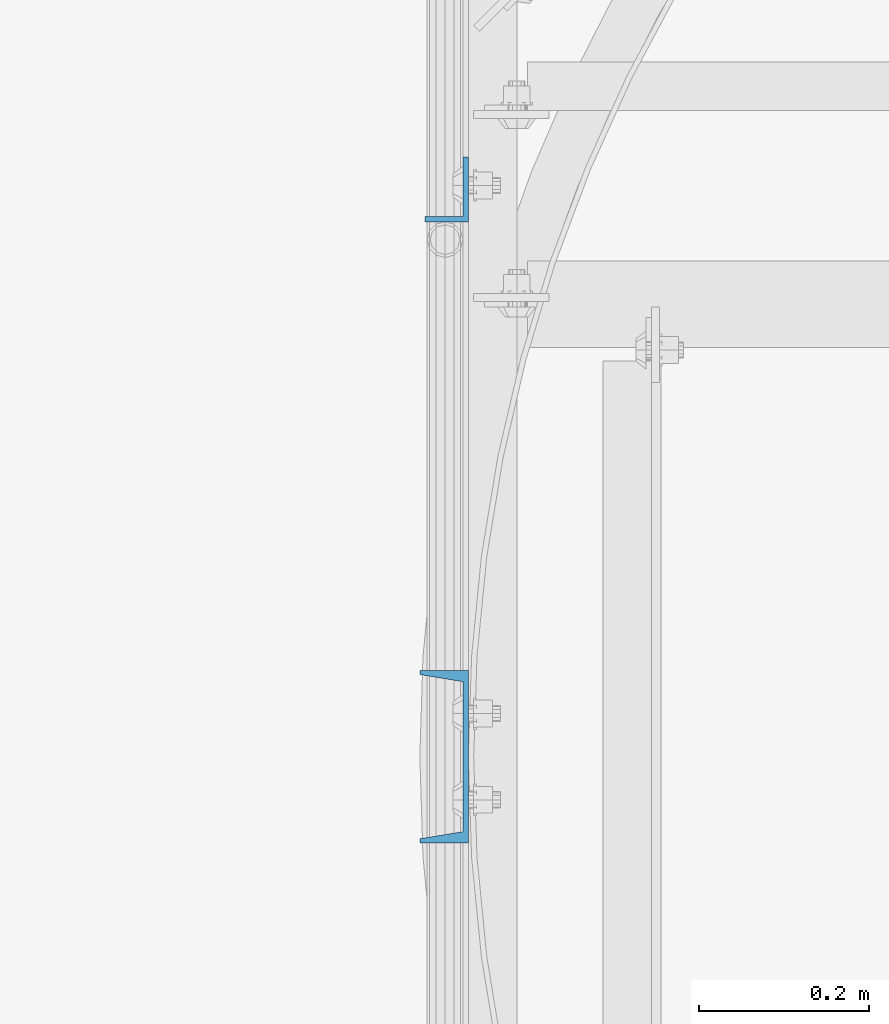
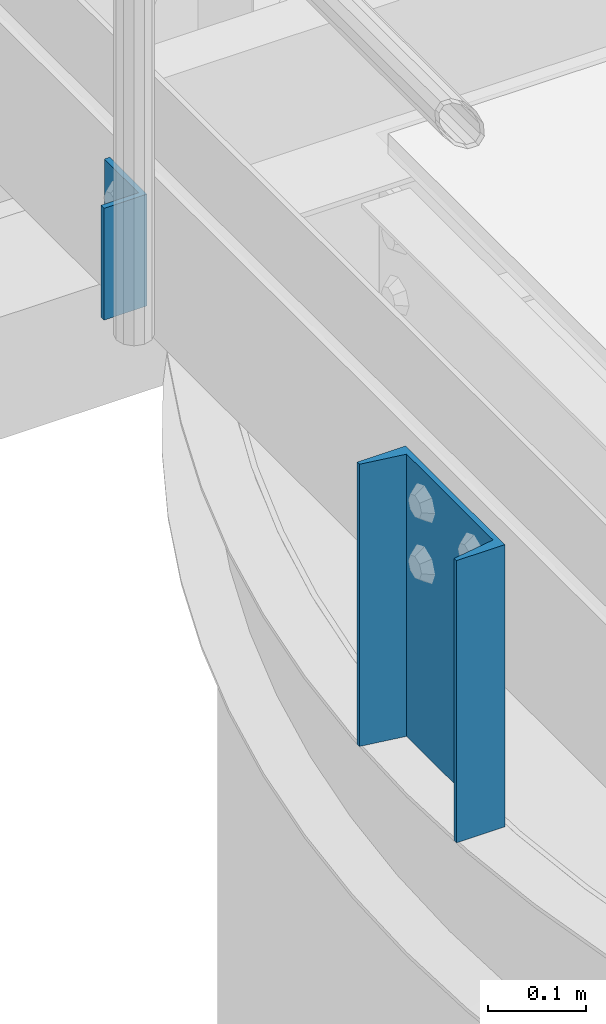
# One storey, part 797 of 1876: 2 columns, 2 elements without a shape of their own.
"""IFC2X3 building model written with IfcOpenShell, lengths in millimetres."""

from ifc_helpers import new_model, si_unit, frame, origin_with_axes, place, context, subcontext, project, spatial, faceted_brep, material, type_object, element, aggregate, save


model = new_model("IFC2X3")

# Units and contexts
model_context = context("Model", 3, precision=1e-05, world=origin_with_axes())
body_context = subcontext(model_context, "Body", "Model", "MODEL_VIEW")
ifc_project = project(units=[si_unit("LENGTHUNIT", "METRE", prefix="MILLI"), si_unit("AREAUNIT", "SQUARE_METRE"), si_unit("VOLUMEUNIT", "CUBIC_METRE"), si_unit("MASSUNIT", "GRAM", prefix="KILO"), si_unit("TIMEUNIT", "SECOND"), si_unit("PLANEANGLEUNIT", "RADIAN"), si_unit("SOLIDANGLEUNIT", "STERADIAN"), si_unit("THERMODYNAMICTEMPERATUREUNIT", "DEGREE_CELSIUS"), si_unit("LUMINOUSINTENSITYUNIT", "LUMEN")], contexts=[model_context])

# Site, building, storey
site_placement = place(None, origin_with_axes())
site = spatial("IfcSite", under=ifc_project, at=site_placement, CompositionType="ELEMENT")
building_placement = place(site_placement, origin_with_axes())
building = spatial("IfcBuilding", under=site, at=building_placement, Name="Undefined", CompositionType="ELEMENT")
storey_placement = place(building_placement, origin_with_axes())
storey = spatial("IfcBuildingStorey", under=building, at=storey_placement, Name="Undefined", CompositionType="ELEMENT", Elevation=0.0)

# Assembly, column
assembly_1_placement = place(storey_placement, origin_with_axes())
assembly_1 = element("IfcElementAssembly", 1, at=assembly_1_placement, inside=storey, Name="HANDRAIL", AssemblyPlace="NOTDEFINED", PredefinedType="RIGID_FRAME")
ifc_material = material(Name="STEEL/A36")
column_type_1 = type_object("IfcColumnType", Name="L3X2X1/4", PredefinedType="NOTDEFINED")
column_1_placement = place(assembly_1_placement, frame((3340.10333884985, -8868.88235546873, 7826.375), z_axis=(0.0, 1.0, 0.0), x_axis=(0.0, 0.0, 1.0)))
column_1 = element("IfcColumn", 2, at=column_1_placement, type_object=column_type_1, material=ifc_material, Name="ANGLE", ObjectType="L3X2X1/4", context=body_context, shape_type="Brep", body=[
    faceted_brep([(0.0, 25.3999999999996, -38.1000000000004), (0.0, 25.3999999999996, 38.1000000000004), (139.7, 25.3999999999996, 38.1000000000004), (139.7, 25.3999999999996, -38.1000000000004), (0.0, 19.0500000000002, 38.1000000000004), (139.7, 19.0500000000002, 38.1000000000004), (0.0, 19.0500000000002, -31.75), (139.7, 19.0500000000002, -31.75), (0.0, -25.3999999999996, -31.75), (139.7, -25.3999999999996, -31.75), (0.0, -25.3999999999996, -38.1000000000004), (139.7, -25.3999999999996, -38.1000000000004)], [[[0, 1, 2, 3]], [[1, 4, 5, 2]], [[4, 6, 7, 5]], [[6, 8, 9, 7]], [[8, 10, 11, 9]], [[10, 0, 3, 11]], [[5, 7, 9, 11, 3, 2]], [[10, 8, 6, 4, 1, 0]]]),
])
aggregate(assembly_1, [column_1])

assembly_2_placement = place(storey_placement, origin_with_axes())
assembly_2 = element("IfcElementAssembly", 3, at=assembly_2_placement, inside=storey, Name="BEAM", AssemblyPlace="NOTDEFINED", PredefinedType="RIGID_FRAME")
column_type_2 = type_object("IfcColumnType", Name="C8X11.5", PredefinedType="NOTDEFINED")
column_2_placement = place(assembly_2_placement, frame((3336.92833884985, -9537.66437988218, 7620.01566278096), z_axis=(0.0, 1.0, 0.0), x_axis=(0.0, 0.0, 1.0)))
column_2 = element("IfcColumn", 4, at=column_2_placement, type_object=column_type_2, material=ifc_material, Name="BEAM", ObjectType="C8X11.5", context=body_context, shape_type="Brep", body=[
    faceted_brep([(0.0, 28.5749999999998, -101.6), (0.0, 28.5749999999998, 101.6), (352.425, 28.5749999999998, 101.6), (352.425, 28.5749999999998, -101.6), (0.0, -28.5749999999998, 101.6), (352.425, -28.5749999999998, 101.6), (0.0, -28.5749999999998, 96.8355950000005), (352.425, -28.5749999999998, 96.8355950000005), (0.0, 22.2250000000004, 88.3723150000005), (352.425, 22.2250000000004, 88.3723150000005), (0.0, 22.2250000000004, -88.3723150000005), (352.425, 22.2250000000004, -88.3723150000005), (0.0, -28.5749999999998, -96.8355950000005), (352.425, -28.5749999999998, -96.8355950000005), (0.0, -28.5749999999998, -101.6), (352.425, -28.5749999999998, -101.6)], [[[0, 1, 2, 3]], [[1, 4, 5, 2]], [[4, 6, 7, 5]], [[6, 8, 9, 7]], [[8, 10, 11, 9]], [[10, 12, 13, 11]], [[12, 14, 15, 13]], [[14, 0, 3, 15]], [[5, 7, 9, 11, 13, 15, 3, 2]], [[14, 12, 10, 8, 6, 4, 1, 0]]]),
])
aggregate(assembly_2, [column_2])

save(model, "model.ifc")
